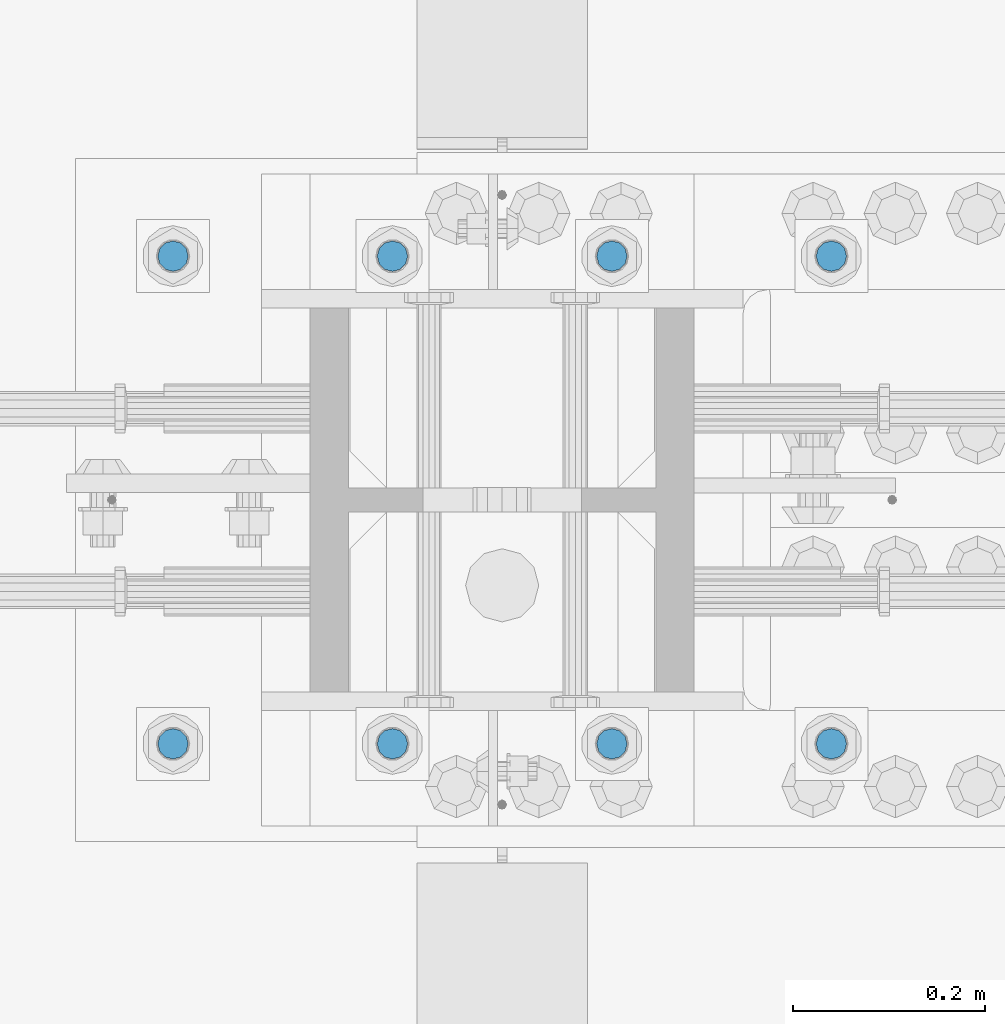
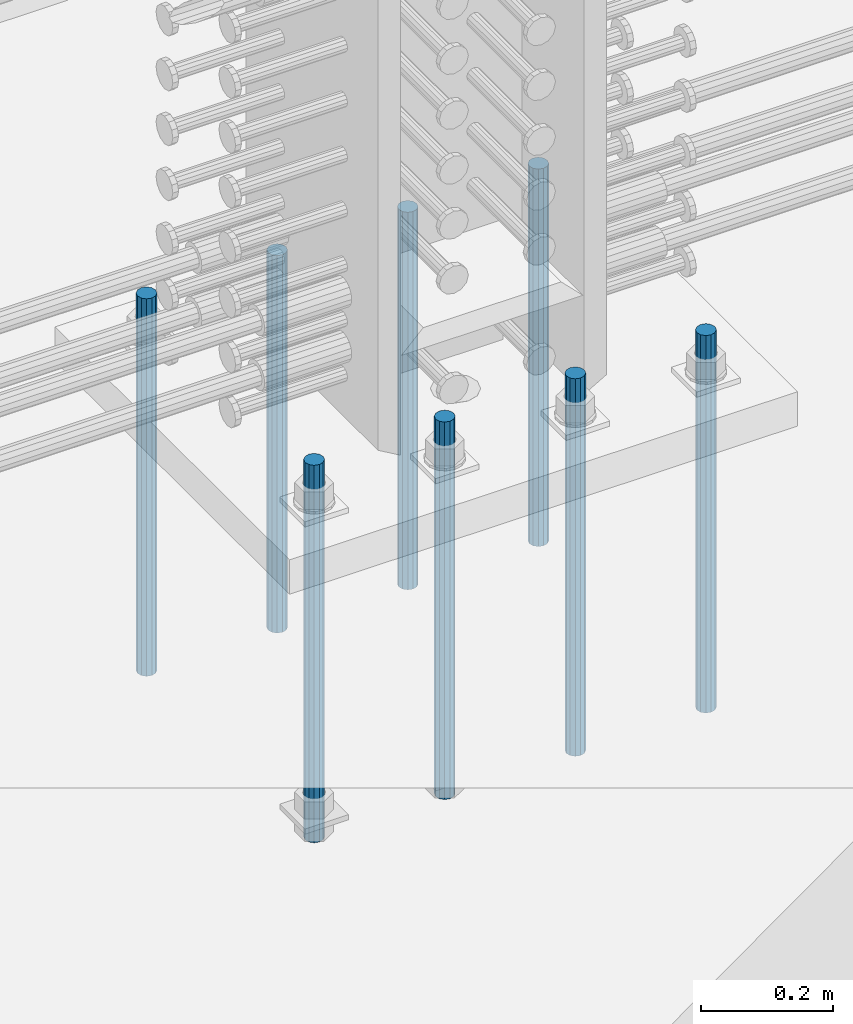
# One storey, part 928 of 1763: 8 columns, 1 element without a shape of its own.
"""IFC2X3 building model written with IfcOpenShell, lengths in millimetres."""

from ifc_helpers import new_model, si_unit, frame, origin_with_axes, place, context, subcontext, project, spatial, faceted_brep, material, type_object, element, aggregate, save


model = new_model("IFC2X3")

# Units and contexts
model_context = context("Model", 3, precision=1e-05, world=origin_with_axes())
body_context = subcontext(model_context, "Body", "Model", "MODEL_VIEW")
ifc_project = project(units=[si_unit("LENGTHUNIT", "METRE", prefix="MILLI"), si_unit("AREAUNIT", "SQUARE_METRE"), si_unit("VOLUMEUNIT", "CUBIC_METRE"), si_unit("MASSUNIT", "GRAM", prefix="KILO"), si_unit("TIMEUNIT", "SECOND"), si_unit("PLANEANGLEUNIT", "RADIAN"), si_unit("SOLIDANGLEUNIT", "STERADIAN"), si_unit("THERMODYNAMICTEMPERATUREUNIT", "DEGREE_CELSIUS"), si_unit("LUMINOUSINTENSITYUNIT", "LUMEN")], contexts=[model_context])

# Site, building, storey
site_placement = place(None, origin_with_axes())
site = spatial("IfcSite", under=ifc_project, at=site_placement, CompositionType="ELEMENT")
building_placement = place(site_placement, origin_with_axes())
building = spatial("IfcBuilding", under=site, at=building_placement, Name="Undefined", CompositionType="ELEMENT")
storey_placement = place(building_placement, origin_with_axes())
storey = spatial("IfcBuildingStorey", under=building, at=storey_placement, Name="Undefined", CompositionType="ELEMENT", Elevation=0.0)

# Assembly, columns
assembly_placement = place(storey_placement, origin_with_axes())
assembly = element("IfcElementAssembly", 1, at=assembly_placement, inside=storey, Name="TEMPLATE", AssemblyPlace="NOTDEFINED", PredefinedType="RIGID_FRAME")
ifc_material = material()
column_type = type_object("IfcColumnType", PredefinedType="NOTDEFINED")
column_1_placement = place(assembly_placement, frame((-72148.1372736972, 203.200000000843, 4000.5), z_axis=(1.0, 0.0, 0.0), x_axis=(0.0, 0.0, -1.0)))
column_1 = element("IfcColumn", 2, at=column_1_placement, type_object=column_type, material=ifc_material, Name="ALL THREADED ROD", context=body_context, shape_type="Brep", body=[
    faceted_brep([(0.0, -15.875, 0.0), (0.0, -13.7481532850798, -7.9375), (698.499, -13.7481532850798, -7.9375), (698.499, -15.875, 0.0), (0.0, -7.9375, -13.748153285078), (698.499, -7.9375, -13.748153285078), (4.91792532185561e-12, 0.0, -15.875), (698.499, 0.0, -15.875), (0.0, 7.9375, -13.748153285078), (698.499, 7.9375, -13.748153285078), (0.0, 13.7481532850798, -7.9375), (698.499, 13.7481532850798, -7.9375), (0.0, 15.875, 0.0), (698.499, 15.875, 0.0), (0.0, 13.7481532850798, 7.9375), (698.499, 13.7481532850798, 7.9375), (0.0, 7.9375, 13.748153285078), (698.499, 7.9375, 13.748153285078), (-1.64518337079051e-12, 0.0, 15.875), (698.499, 0.0, 15.875), (0.0, -7.9375, 13.748153285078), (698.499, -7.9375, 13.748153285078), (0.0, -13.7481532850798, 7.9375), (698.499, -13.7481532850798, 7.9375)], [[[0, 1, 2, 3]], [[1, 4, 5, 2]], [[4, 6, 7, 5]], [[6, 8, 9, 7]], [[8, 10, 11, 9]], [[10, 12, 13, 11]], [[12, 14, 15, 13]], [[14, 16, 17, 15]], [[16, 18, 19, 17]], [[18, 20, 21, 19]], [[20, 22, 23, 21]], [[22, 0, 3, 23]], [[5, 7, 9, 11, 13, 15, 17, 19, 21, 23, 3, 2]], [[22, 20, 18, 16, 14, 12, 10, 8, 6, 4, 1, 0]]]),
])
column_2_placement = place(assembly_placement, frame((-72148.1372736972, 711.200000000843, 4000.5), z_axis=(-1.0, 0.0, 0.0), x_axis=(0.0, 0.0, -1.0)))
column_2 = element("IfcColumn", 3, at=column_2_placement, type_object=column_type, material=ifc_material, Name="ALL THREADED ROD", context=body_context, shape_type="Brep", body=[
    faceted_brep([(0.0, -15.875, 0.0), (0.0, -13.7481532850798, -7.9375), (698.499, -13.7481532850798, -7.9375), (698.499, -15.875, 0.0), (0.0, -7.9375, -13.748153285078), (698.499, -7.9375, -13.748153285078), (4.91792532185561e-12, 0.0, -15.875), (698.499, 0.0, -15.875), (0.0, 7.9375, -13.748153285078), (698.499, 7.9375, -13.748153285078), (0.0, 13.7481532850798, -7.9375), (698.499, 13.7481532850798, -7.9375), (0.0, 15.875, 0.0), (698.499, 15.875, 0.0), (0.0, 13.7481532850798, 7.9375), (698.499, 13.7481532850798, 7.9375), (0.0, 7.9375, 13.748153285078), (698.499, 7.9375, 13.748153285078), (-1.64518337079051e-12, 0.0, 15.875), (698.499, 0.0, 15.875), (0.0, -7.9375, 13.748153285078), (698.499, -7.9375, 13.748153285078), (0.0, -13.7481532850798, 7.9375), (698.499, -13.7481532850798, 7.9375)], [[[0, 1, 2, 3]], [[1, 4, 5, 2]], [[4, 6, 7, 5]], [[6, 8, 9, 7]], [[8, 10, 11, 9]], [[10, 12, 13, 11]], [[12, 14, 15, 13]], [[14, 16, 17, 15]], [[16, 18, 19, 17]], [[18, 20, 21, 19]], [[20, 22, 23, 21]], [[22, 0, 3, 23]], [[5, 7, 9, 11, 13, 15, 17, 19, 21, 23, 3, 2]], [[22, 20, 18, 16, 14, 12, 10, 8, 6, 4, 1, 0]]]),
])
column_3_placement = place(assembly_placement, frame((-72376.7372736972, 203.200000000843, 4000.5), z_axis=(1.0, 0.0, 0.0), x_axis=(0.0, 0.0, -1.0)))
column_3 = element("IfcColumn", 4, at=column_3_placement, type_object=column_type, material=ifc_material, Name="ALL THREADED ROD", context=body_context, shape_type="Brep", body=[
    faceted_brep([(0.0, -15.875, 0.0), (0.0, -13.7481532850798, -7.9375), (698.499, -13.7481532850798, -7.9375), (698.499, -15.875, 0.0), (0.0, -7.9375, -13.748153285078), (698.499, -7.9375, -13.748153285078), (4.91792532185561e-12, 0.0, -15.875), (698.499, 0.0, -15.875), (0.0, 7.9375, -13.748153285078), (698.499, 7.9375, -13.748153285078), (0.0, 13.7481532850798, -7.9375), (698.499, 13.7481532850798, -7.9375), (0.0, 15.875, 0.0), (698.499, 15.875, 0.0), (0.0, 13.7481532850798, 7.9375), (698.499, 13.7481532850798, 7.9375), (0.0, 7.9375, 13.748153285078), (698.499, 7.9375, 13.748153285078), (-1.64518337079051e-12, 0.0, 15.875), (698.499, 0.0, 15.875), (0.0, -7.9375, 13.748153285078), (698.499, -7.9375, 13.748153285078), (0.0, -13.7481532850798, 7.9375), (698.499, -13.7481532850798, 7.9375)], [[[0, 1, 2, 3]], [[1, 4, 5, 2]], [[4, 6, 7, 5]], [[6, 8, 9, 7]], [[8, 10, 11, 9]], [[10, 12, 13, 11]], [[12, 14, 15, 13]], [[14, 16, 17, 15]], [[16, 18, 19, 17]], [[18, 20, 21, 19]], [[20, 22, 23, 21]], [[22, 0, 3, 23]], [[5, 7, 9, 11, 13, 15, 17, 19, 21, 23, 3, 2]], [[22, 20, 18, 16, 14, 12, 10, 8, 6, 4, 1, 0]]]),
])
column_4_placement = place(assembly_placement, frame((-72376.7372736972, 711.200000000843, 4000.5), z_axis=(-1.0, 0.0, 0.0), x_axis=(0.0, 0.0, -1.0)))
column_4 = element("IfcColumn", 5, at=column_4_placement, type_object=column_type, material=ifc_material, Name="ALL THREADED ROD", context=body_context, shape_type="Brep", body=[
    faceted_brep([(0.0, -15.875, 0.0), (0.0, -13.7481532850798, -7.9375), (698.499, -13.7481532850798, -7.9375), (698.499, -15.875, 0.0), (0.0, -7.9375, -13.748153285078), (698.499, -7.9375, -13.748153285078), (4.91792532185561e-12, 0.0, -15.875), (698.499, 0.0, -15.875), (0.0, 7.9375, -13.748153285078), (698.499, 7.9375, -13.748153285078), (0.0, 13.7481532850798, -7.9375), (698.499, 13.7481532850798, -7.9375), (0.0, 15.875, 0.0), (698.499, 15.875, 0.0), (0.0, 13.7481532850798, 7.9375), (698.499, 13.7481532850798, 7.9375), (0.0, 7.9375, 13.748153285078), (698.499, 7.9375, 13.748153285078), (-1.64518337079051e-12, 0.0, 15.875), (698.499, 0.0, 15.875), (0.0, -7.9375, 13.748153285078), (698.499, -7.9375, 13.748153285078), (0.0, -13.7481532850798, 7.9375), (698.499, -13.7481532850798, 7.9375)], [[[0, 1, 2, 3]], [[1, 4, 5, 2]], [[4, 6, 7, 5]], [[6, 8, 9, 7]], [[8, 10, 11, 9]], [[10, 12, 13, 11]], [[12, 14, 15, 13]], [[14, 16, 17, 15]], [[16, 18, 19, 17]], [[18, 20, 21, 19]], [[20, 22, 23, 21]], [[22, 0, 3, 23]], [[5, 7, 9, 11, 13, 15, 17, 19, 21, 23, 3, 2]], [[22, 20, 18, 16, 14, 12, 10, 8, 6, 4, 1, 0]]]),
])
column_5_placement = place(assembly_placement, frame((-72605.3372736972, 203.200000000843, 4000.5), z_axis=(1.0, 0.0, 0.0), x_axis=(0.0, 0.0, -1.0)))
column_5 = element("IfcColumn", 6, at=column_5_placement, type_object=column_type, material=ifc_material, Name="ALL THREADED ROD", context=body_context, shape_type="Brep", body=[
    faceted_brep([(0.0, -15.875, 0.0), (0.0, -13.7481532850798, -7.9375), (698.499, -13.7481532850798, -7.9375), (698.499, -15.875, 0.0), (0.0, -7.9375, -13.748153285078), (698.499, -7.9375, -13.748153285078), (4.91792532185561e-12, 0.0, -15.875), (698.499, 0.0, -15.875), (0.0, 7.9375, -13.748153285078), (698.499, 7.9375, -13.748153285078), (0.0, 13.7481532850798, -7.9375), (698.499, 13.7481532850798, -7.9375), (0.0, 15.875, 0.0), (698.499, 15.875, 0.0), (0.0, 13.7481532850798, 7.9375), (698.499, 13.7481532850798, 7.9375), (0.0, 7.9375, 13.748153285078), (698.499, 7.9375, 13.748153285078), (-1.64518337079051e-12, 0.0, 15.875), (698.499, 0.0, 15.875), (0.0, -7.9375, 13.748153285078), (698.499, -7.9375, 13.748153285078), (0.0, -13.7481532850798, 7.9375), (698.499, -13.7481532850798, 7.9375)], [[[0, 1, 2, 3]], [[1, 4, 5, 2]], [[4, 6, 7, 5]], [[6, 8, 9, 7]], [[8, 10, 11, 9]], [[10, 12, 13, 11]], [[12, 14, 15, 13]], [[14, 16, 17, 15]], [[16, 18, 19, 17]], [[18, 20, 21, 19]], [[20, 22, 23, 21]], [[22, 0, 3, 23]], [[5, 7, 9, 11, 13, 15, 17, 19, 21, 23, 3, 2]], [[22, 20, 18, 16, 14, 12, 10, 8, 6, 4, 1, 0]]]),
])
column_6_placement = place(assembly_placement, frame((-72605.3372736972, 711.200000000843, 4000.5), z_axis=(-1.0, 0.0, 0.0), x_axis=(0.0, 0.0, -1.0)))
column_6 = element("IfcColumn", 7, at=column_6_placement, type_object=column_type, material=ifc_material, Name="ALL THREADED ROD", context=body_context, shape_type="Brep", body=[
    faceted_brep([(0.0, -15.875, 0.0), (0.0, -13.7481532850798, -7.9375), (698.499, -13.7481532850798, -7.9375), (698.499, -15.875, 0.0), (0.0, -7.9375, -13.748153285078), (698.499, -7.9375, -13.748153285078), (4.91792532185561e-12, 0.0, -15.875), (698.499, 0.0, -15.875), (0.0, 7.9375, -13.748153285078), (698.499, 7.9375, -13.748153285078), (0.0, 13.7481532850798, -7.9375), (698.499, 13.7481532850798, -7.9375), (0.0, 15.875, 0.0), (698.499, 15.875, 0.0), (0.0, 13.7481532850798, 7.9375), (698.499, 13.7481532850798, 7.9375), (0.0, 7.9375, 13.748153285078), (698.499, 7.9375, 13.748153285078), (-1.64518337079051e-12, 0.0, 15.875), (698.499, 0.0, 15.875), (0.0, -7.9375, 13.748153285078), (698.499, -7.9375, 13.748153285078), (0.0, -13.7481532850798, 7.9375), (698.499, -13.7481532850798, 7.9375)], [[[0, 1, 2, 3]], [[1, 4, 5, 2]], [[4, 6, 7, 5]], [[6, 8, 9, 7]], [[8, 10, 11, 9]], [[10, 12, 13, 11]], [[12, 14, 15, 13]], [[14, 16, 17, 15]], [[16, 18, 19, 17]], [[18, 20, 21, 19]], [[20, 22, 23, 21]], [[22, 0, 3, 23]], [[5, 7, 9, 11, 13, 15, 17, 19, 21, 23, 3, 2]], [[22, 20, 18, 16, 14, 12, 10, 8, 6, 4, 1, 0]]]),
])
column_7_placement = place(assembly_placement, frame((-72833.9372736972, 203.200000000843, 4000.5), z_axis=(1.0, 0.0, 0.0), x_axis=(0.0, 0.0, -1.0)))
column_7 = element("IfcColumn", 8, at=column_7_placement, type_object=column_type, material=ifc_material, Name="ALL THREADED ROD", context=body_context, shape_type="Brep", body=[
    faceted_brep([(0.0, -15.875, 0.0), (0.0, -13.7481532850798, -7.9375), (698.499, -13.7481532850798, -7.9375), (698.499, -15.875, 0.0), (0.0, -7.9375, -13.748153285078), (698.499, -7.9375, -13.748153285078), (4.91792532185561e-12, 0.0, -15.875), (698.499, 0.0, -15.875), (0.0, 7.9375, -13.748153285078), (698.499, 7.9375, -13.748153285078), (0.0, 13.7481532850798, -7.9375), (698.499, 13.7481532850798, -7.9375), (0.0, 15.875, 0.0), (698.499, 15.875, 0.0), (0.0, 13.7481532850798, 7.9375), (698.499, 13.7481532850798, 7.9375), (0.0, 7.9375, 13.748153285078), (698.499, 7.9375, 13.748153285078), (-1.64518337079051e-12, 0.0, 15.875), (698.499, 0.0, 15.875), (0.0, -7.9375, 13.748153285078), (698.499, -7.9375, 13.748153285078), (0.0, -13.7481532850798, 7.9375), (698.499, -13.7481532850798, 7.9375)], [[[0, 1, 2, 3]], [[1, 4, 5, 2]], [[4, 6, 7, 5]], [[6, 8, 9, 7]], [[8, 10, 11, 9]], [[10, 12, 13, 11]], [[12, 14, 15, 13]], [[14, 16, 17, 15]], [[16, 18, 19, 17]], [[18, 20, 21, 19]], [[20, 22, 23, 21]], [[22, 0, 3, 23]], [[5, 7, 9, 11, 13, 15, 17, 19, 21, 23, 3, 2]], [[22, 20, 18, 16, 14, 12, 10, 8, 6, 4, 1, 0]]]),
])
column_8_placement = place(assembly_placement, frame((-72833.9372736972, 711.200000000843, 4000.5), z_axis=(-1.0, 0.0, 0.0), x_axis=(0.0, 0.0, -1.0)))
column_8 = element("IfcColumn", 9, at=column_8_placement, type_object=column_type, material=ifc_material, Name="ALL THREADED ROD", context=body_context, shape_type="Brep", body=[
    faceted_brep([(0.0, -15.875, 0.0), (0.0, -13.7481532850798, -7.9375), (698.499, -13.7481532850798, -7.9375), (698.499, -15.875, 0.0), (0.0, -7.9375, -13.748153285078), (698.499, -7.9375, -13.748153285078), (4.91792532185561e-12, 0.0, -15.875), (698.499, 0.0, -15.875), (0.0, 7.9375, -13.748153285078), (698.499, 7.9375, -13.748153285078), (0.0, 13.7481532850798, -7.9375), (698.499, 13.7481532850798, -7.9375), (0.0, 15.875, 0.0), (698.499, 15.875, 0.0), (0.0, 13.7481532850798, 7.9375), (698.499, 13.7481532850798, 7.9375), (0.0, 7.9375, 13.748153285078), (698.499, 7.9375, 13.748153285078), (-1.64518337079051e-12, 0.0, 15.875), (698.499, 0.0, 15.875), (0.0, -7.9375, 13.748153285078), (698.499, -7.9375, 13.748153285078), (0.0, -13.7481532850798, 7.9375), (698.499, -13.7481532850798, 7.9375)], [[[0, 1, 2, 3]], [[1, 4, 5, 2]], [[4, 6, 7, 5]], [[6, 8, 9, 7]], [[8, 10, 11, 9]], [[10, 12, 13, 11]], [[12, 14, 15, 13]], [[14, 16, 17, 15]], [[16, 18, 19, 17]], [[18, 20, 21, 19]], [[20, 22, 23, 21]], [[22, 0, 3, 23]], [[5, 7, 9, 11, 13, 15, 17, 19, 21, 23, 3, 2]], [[22, 20, 18, 16, 14, 12, 10, 8, 6, 4, 1, 0]]]),
])
aggregate(assembly, [column_1, column_2, column_3, column_4, column_5, column_6, column_7, column_8])

save(model, "model.ifc")
